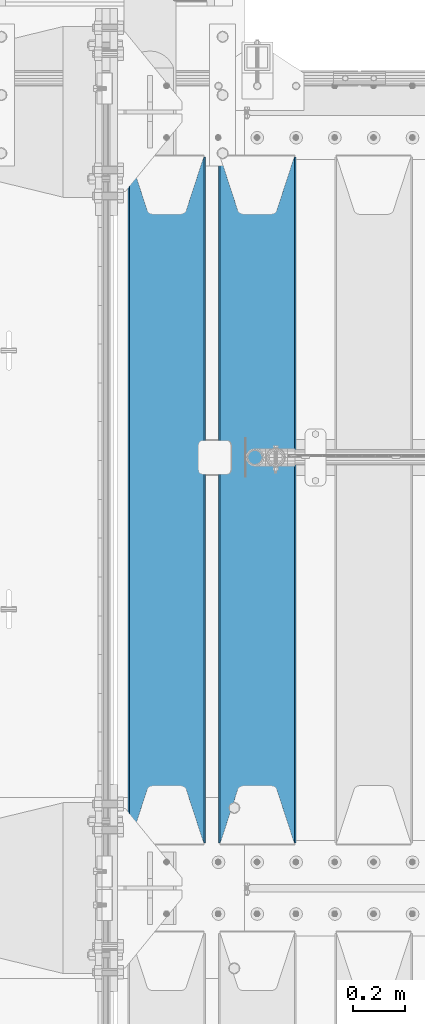
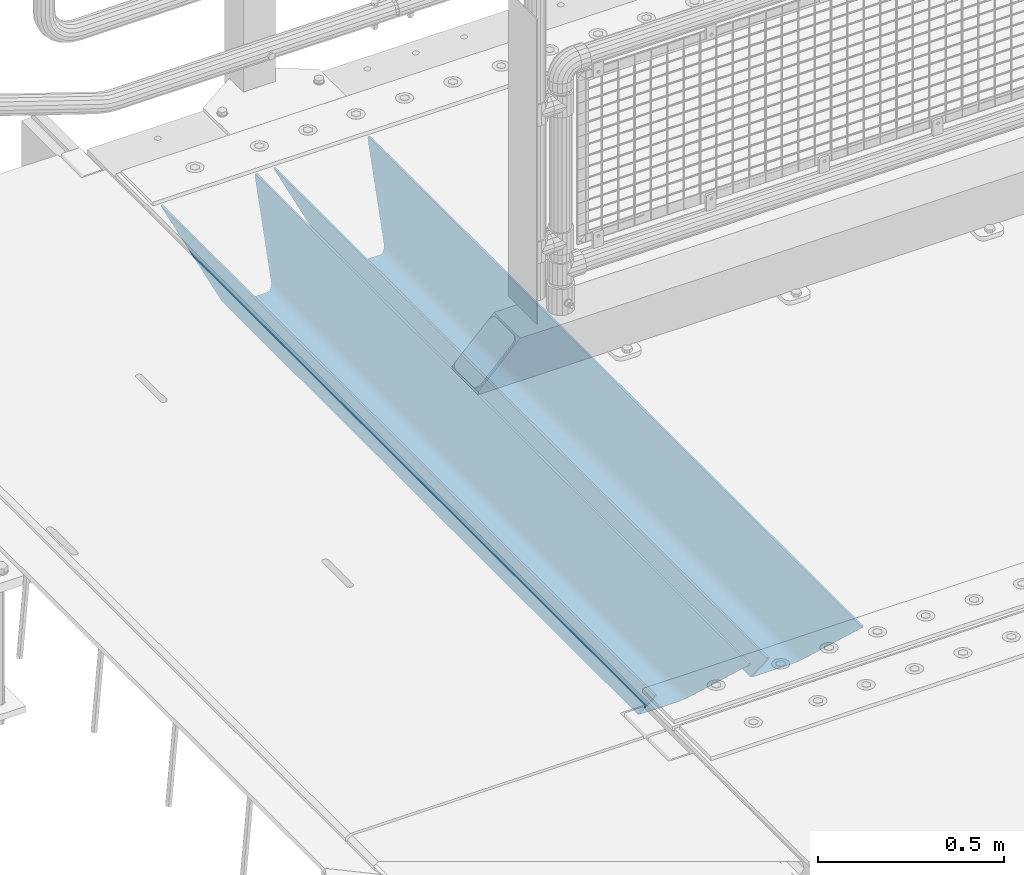
# One storey, part 127 of 270: 2 beams.
"""IFC2X3 building model written with IfcOpenShell, lengths in millimetres."""

from ifc_helpers import new_model, si_unit, frame, origin_with_axes, place, context, subcontext, project, spatial, faceted_brep, material, type_object, element, save


model = new_model("IFC2X3")

# Units and contexts
model_context = context("Model", 3, precision=1e-05, world=origin_with_axes())
body_context = subcontext(model_context, "Body", "Model", "MODEL_VIEW")
ifc_project = project(units=[si_unit("LENGTHUNIT", "METRE", prefix="MILLI"), si_unit("AREAUNIT", "SQUARE_METRE"), si_unit("VOLUMEUNIT", "CUBIC_METRE"), si_unit("MASSUNIT", "GRAM", prefix="KILO"), si_unit("TIMEUNIT", "SECOND"), si_unit("PLANEANGLEUNIT", "RADIAN"), si_unit("SOLIDANGLEUNIT", "STERADIAN"), si_unit("THERMODYNAMICTEMPERATUREUNIT", "DEGREE_CELSIUS"), si_unit("LUMINOUSINTENSITYUNIT", "LUMEN")], contexts=[model_context])

# Site, building, storey
site_placement = place(None, origin_with_axes())
site = spatial("IfcSite", under=ifc_project, at=site_placement, CompositionType="ELEMENT")
building_placement = place(site_placement, origin_with_axes())
building = spatial("IfcBuilding", under=site, at=building_placement, Name="Standard", CompositionType="ELEMENT")
storey_placement = place(building_placement, origin_with_axes())
storey = spatial("IfcBuildingStorey", under=building, at=storey_placement, Name="Undefined", CompositionType="ELEMENT", Elevation=0.0)

# Beams
ifc_material = material(Name="STEEL/S355N")
beam_type = type_object("IfcBeamType", PredefinedType="NOTDEFINED")
beam_1_placement = place(storey_placement, frame((550.0, -17825.0, -115.0), z_axis=(0.0, 0.0, 1.0), x_axis=(0.0, 1.0, 0.0)))
element("IfcBeam", 1, at=beam_1_placement, inside=storey, type_object=beam_type, material=ifc_material, context=body_context, shape_type="Brep", body=[
    faceted_brep([(0.0, 150.0, 115.0), (0.0, 143.689999999999, 115.0), (2650.00000000297, 143.689999999999, 115.0), (2650.00000000297, 150.0, 115.0), (2650.00000000297, 142.059565218398, 110.000000003096), (2650.00000000297, 148.3695652184, 110.000000003096), (2441.90079219209, -80.1103600731112, -98.0992078077845), (2437.7588105432, -77.5672621345584, -102.241189456673), (2434.06523489747, -74.4080125315522, -105.934765102404), (2430.9108609509, -70.710272125576, -109.089139048974), (2428.37322971128, -66.5649389910068, -111.626770288588), (2426.51472138055, -62.0739139532889, -113.485278619323), (2425.38102192092, -57.3475956567672, -114.618978078955), (2424.99999999987, -52.5021667386536, -115.0), (2424.99999999987, 52.5021667386536, -115.0), (2425.38102192092, 57.3475956567672, -114.618978078955), (2426.51472138055, 62.0739139532889, -113.485278619323), (2428.37322971128, 66.5649389910068, -111.626770288588), (2430.9108609509, 70.710272125576, -109.089139048974), (2434.06523489747, 74.4080125315522, -105.934765102404), (2437.7588105432, 77.5672621345584, -102.241189456673), (2441.90079219209, 80.1103600731112, -98.0992078077846), (2446.38936140511, 81.9747917625791, -93.6106385947584), (2448.2494850041, 76.2713538057251, -91.7505149957729), (2444.62967112263, 74.76777986261, -95.3703288772456), (2441.28936334126, 72.7168944282894, -98.710636658607), (2438.31067330439, 70.1691124903846, -101.689326695487), (2435.76682334747, 67.1870637758839, -104.233176652398), (2433.72034654133, 63.8440531834895, -106.279653458539), (2432.22154950042, 60.222258798236, -107.778450499454), (2431.30727574265, 56.4107117849089, -108.692724257221), (2430.99999999987, 52.5031078186876, -109.0), (2430.99999999987, -52.5031078186876, -109.0), (2431.30727574265, -56.4107117849089, -108.692724257221), (2432.22154950042, -60.222258798236, -107.778450499454), (2433.72034654133, -63.8440531834895, -106.279653458539), (2435.76682334747, -67.1870637758839, -104.233176652398), (2438.31067330438, -70.1691124903846, -101.689326695487), (2441.28936334126, -72.7168944282894, -98.7106366586071), (2444.62967112263, -74.76777986261, -95.3703288772457), (2448.2494850041, -76.2713538057251, -91.7505149957729), (2650.00000000297, -142.059565218398, 110.000000003096), (2650.00000000297, -148.3695652184, 110.000000003096), (2446.38936140511, -81.9747917625791, -93.6106385947584), (2650.00000000297, -143.689999999999, 115.0), (2650.00000000297, -150.0, 115.0), (0.0, -143.689999999999, 115.0), (0.0, -150.0, 115.0), (0.0, -148.369565218261, 110.000000002672), (203.610638597431, -81.9747917625791, -93.6106385947584), (208.099207810457, -80.1103600731112, -98.0992078077845), (212.241189459342, -77.5672621345584, -102.241189456673), (215.934765105078, -74.4080125315522, -105.934765102404), (219.089139051644, -70.710272125576, -109.089139048974), (221.626770291259, -66.5649389910068, -111.626770288588), (223.485278621993, -62.0739139532889, -113.485278619323), (224.618978081628, -57.3475956567672, -114.618978078955), (225.00000000267, -52.5021667386536, -115.0), (225.00000000267, 52.5021667386536, -115.0), (224.618978081628, 57.3475956567672, -114.618978078955), (223.485278621993, 62.0739139532889, -113.485278619323), (221.626770291259, 66.5649389910068, -111.626770288588), (219.089139051644, 70.710272125576, -109.089139048974), (215.934765105078, 74.4080125315522, -105.934765102404), (212.241189459342, 77.5672621345584, -102.241189456673), (208.099207810457, 80.1103600731112, -98.0992078077846), (203.610638597431, 81.9747917625791, -93.6106385947584), (0.0, 148.369565218261, 110.000000002672), (0.0, 142.05956521826, 110.000000002672), (201.750514998446, 76.2713538057251, -91.7505149957729), (205.370328879915, 74.76777986261, -95.3703288772456), (208.710636661279, 72.7168944282894, -98.710636658607), (211.689326698157, 70.1691124903846, -101.689326695487), (214.233176655071, 67.1870637758839, -104.233176652398), (216.27965346121, 63.8440531834895, -106.279653458539), (217.778450502126, 60.222258798236, -107.778450499454), (218.692724259894, 56.4107117849089, -108.692724257221), (219.00000000267, 52.5031078186876, -109.0), (219.00000000267, -52.5031078186876, -109.0), (218.692724259894, -56.4107117849089, -108.692724257221), (217.778450502123, -60.222258798236, -107.778450499454), (216.27965346121, -63.8440531834895, -106.279653458539), (214.233176655071, -67.1870637758839, -104.233176652398), (211.689326698157, -70.1691124903846, -101.689326695487), (208.710636661279, -72.7168944282894, -98.7106366586071), (205.370328879915, -74.76777986261, -95.3703288772457), (201.750514998446, -76.2713538057251, -91.7505149957729), (0.0, -142.05956521826, 110.000000002672)], [[[0, 1, 2, 3]], [[3, 2, 4, 5]], [[6, 7, 8, 9, 10, 11, 12, 13, 14, 15, 16, 17, 18, 19, 20, 21, 22, 5, 4, 23, 24, 25, 26, 27, 28, 29, 30, 31, 32, 33, 34, 35, 36, 37, 38, 39, 40, 41, 42, 43]], [[44, 45, 42, 41]], [[46, 47, 45, 44]], [[43, 42, 45, 47, 48, 49]], [[6, 43, 49, 50]], [[7, 6, 50, 51]], [[8, 7, 51, 52]], [[9, 8, 52, 53]], [[10, 9, 53, 54]], [[11, 10, 54, 55]], [[12, 11, 55, 56]], [[13, 12, 56, 57]], [[14, 13, 57, 58]], [[15, 14, 58, 59]], [[16, 15, 59, 60]], [[17, 16, 60, 61]], [[18, 17, 61, 62]], [[19, 18, 62, 63]], [[20, 19, 63, 64]], [[21, 20, 64, 65]], [[22, 21, 65, 66]], [[0, 3, 5, 22, 66, 67]], [[1, 0, 67, 68]], [[23, 4, 2, 1, 68, 69]], [[24, 23, 69, 70]], [[25, 24, 70, 71]], [[26, 25, 71, 72]], [[27, 26, 72, 73]], [[28, 27, 73, 74]], [[29, 28, 74, 75]], [[30, 29, 75, 76]], [[31, 30, 76, 77]], [[32, 31, 77, 78]], [[33, 32, 78, 79]], [[34, 33, 79, 80]], [[35, 34, 80, 81]], [[36, 35, 81, 82]], [[37, 36, 82, 83]], [[38, 37, 83, 84]], [[39, 38, 84, 85]], [[40, 39, 85, 86]], [[46, 44, 41, 40, 86, 87]], [[47, 46, 87, 48]], [[86, 85, 84, 83, 82, 81, 80, 79, 78, 77, 76, 75, 74, 73, 72, 71, 70, 69, 68, 67, 66, 65, 64, 63, 62, 61, 60, 59, 58, 57, 56, 55, 54, 53, 52, 51, 50, 49, 48, 87]]]),
])
beam_2_placement = place(storey_placement, frame((200.0, -17825.0, -115.0), z_axis=(0.0, 0.0, 1.0), x_axis=(0.0, 1.0, 0.0)))
element("IfcBeam", 2, at=beam_2_placement, inside=storey, type_object=beam_type, material=ifc_material, context=body_context, shape_type="Brep", body=[
    faceted_brep([(0.0, 150.0, 115.0), (0.0, 143.689999999999, 115.0), (2650.00000000297, 143.689999999999, 115.0), (2650.00000000297, 150.0, 115.0), (2650.00000000297, 142.059565218398, 110.000000003096), (2650.00000000297, 148.3695652184, 110.000000003096), (2441.90079219209, -80.1103600731112, -98.0992078077845), (2437.7588105432, -77.5672621345584, -102.241189456673), (2434.06523489747, -74.4080125315522, -105.934765102404), (2430.9108609509, -70.710272125576, -109.089139048974), (2428.37322971128, -66.5649389910068, -111.626770288588), (2426.51472138055, -62.0739139532889, -113.485278619323), (2425.38102192092, -57.3475956567672, -114.618978078955), (2424.99999999987, -52.5021667386536, -115.0), (2424.99999999987, 52.5021667386536, -115.0), (2425.38102192092, 57.3475956567672, -114.618978078955), (2426.51472138055, 62.0739139532889, -113.485278619323), (2428.37322971128, 66.5649389910068, -111.626770288588), (2430.9108609509, 70.710272125576, -109.089139048974), (2434.06523489747, 74.4080125315522, -105.934765102404), (2437.7588105432, 77.5672621345584, -102.241189456673), (2441.90079219209, 80.1103600731112, -98.0992078077846), (2446.38936140511, 81.9747917625791, -93.6106385947584), (2448.2494850041, 76.2713538057251, -91.7505149957729), (2444.62967112263, 74.76777986261, -95.3703288772456), (2441.28936334126, 72.7168944282894, -98.710636658607), (2438.31067330439, 70.1691124903846, -101.689326695487), (2435.76682334747, 67.1870637758839, -104.233176652398), (2433.72034654133, 63.8440531834895, -106.279653458539), (2432.22154950042, 60.222258798236, -107.778450499454), (2431.30727574265, 56.4107117849089, -108.692724257221), (2430.99999999987, 52.5031078186876, -109.0), (2430.99999999987, -52.5031078186876, -109.0), (2431.30727574265, -56.4107117849089, -108.692724257221), (2432.22154950042, -60.222258798236, -107.778450499454), (2433.72034654133, -63.8440531834895, -106.279653458539), (2435.76682334747, -67.1870637758839, -104.233176652398), (2438.31067330438, -70.1691124903846, -101.689326695487), (2441.28936334126, -72.7168944282894, -98.7106366586071), (2444.62967112263, -74.76777986261, -95.3703288772457), (2448.2494850041, -76.2713538057251, -91.7505149957729), (2650.00000000297, -142.059565218398, 110.000000003096), (2650.00000000297, -148.3695652184, 110.000000003096), (2446.38936140511, -81.9747917625791, -93.6106385947584), (2650.00000000297, -143.689999999999, 115.0), (2650.00000000297, -150.0, 115.0), (0.0, -143.689999999999, 115.0), (0.0, -150.0, 115.0), (0.0, -148.369565218261, 110.000000002672), (203.610638597431, -81.9747917625791, -93.6106385947584), (208.099207810457, -80.1103600731112, -98.0992078077845), (212.241189459342, -77.5672621345584, -102.241189456673), (215.934765105078, -74.4080125315522, -105.934765102404), (219.089139051644, -70.710272125576, -109.089139048974), (221.626770291259, -66.5649389910068, -111.626770288588), (223.485278621993, -62.0739139532889, -113.485278619323), (224.618978081628, -57.3475956567672, -114.618978078955), (225.00000000267, -52.5021667386536, -115.0), (225.00000000267, 52.5021667386536, -115.0), (224.618978081628, 57.3475956567672, -114.618978078955), (223.485278621993, 62.0739139532889, -113.485278619323), (221.626770291259, 66.5649389910068, -111.626770288588), (219.089139051644, 70.710272125576, -109.089139048974), (215.934765105078, 74.4080125315522, -105.934765102404), (212.241189459342, 77.5672621345584, -102.241189456673), (208.099207810457, 80.1103600731112, -98.0992078077846), (203.610638597431, 81.9747917625791, -93.6106385947584), (0.0, 148.369565218261, 110.000000002672), (0.0, 142.05956521826, 110.000000002672), (201.750514998446, 76.2713538057251, -91.7505149957729), (205.370328879915, 74.76777986261, -95.3703288772456), (208.710636661279, 72.7168944282894, -98.710636658607), (211.689326698157, 70.1691124903846, -101.689326695487), (214.233176655071, 67.1870637758839, -104.233176652398), (216.27965346121, 63.8440531834895, -106.279653458539), (217.778450502126, 60.222258798236, -107.778450499454), (218.692724259894, 56.4107117849089, -108.692724257221), (219.00000000267, 52.5031078186876, -109.0), (219.00000000267, -52.5031078186876, -109.0), (218.692724259894, -56.4107117849089, -108.692724257221), (217.778450502123, -60.222258798236, -107.778450499454), (216.27965346121, -63.8440531834895, -106.279653458539), (214.233176655071, -67.1870637758839, -104.233176652398), (211.689326698157, -70.1691124903846, -101.689326695487), (208.710636661279, -72.7168944282894, -98.7106366586071), (205.370328879915, -74.76777986261, -95.3703288772457), (201.750514998446, -76.2713538057251, -91.7505149957729), (0.0, -142.05956521826, 110.000000002672)], [[[0, 1, 2, 3]], [[3, 2, 4, 5]], [[6, 7, 8, 9, 10, 11, 12, 13, 14, 15, 16, 17, 18, 19, 20, 21, 22, 5, 4, 23, 24, 25, 26, 27, 28, 29, 30, 31, 32, 33, 34, 35, 36, 37, 38, 39, 40, 41, 42, 43]], [[44, 45, 42, 41]], [[46, 47, 45, 44]], [[43, 42, 45, 47, 48, 49]], [[6, 43, 49, 50]], [[7, 6, 50, 51]], [[8, 7, 51, 52]], [[9, 8, 52, 53]], [[10, 9, 53, 54]], [[11, 10, 54, 55]], [[12, 11, 55, 56]], [[13, 12, 56, 57]], [[14, 13, 57, 58]], [[15, 14, 58, 59]], [[16, 15, 59, 60]], [[17, 16, 60, 61]], [[18, 17, 61, 62]], [[19, 18, 62, 63]], [[20, 19, 63, 64]], [[21, 20, 64, 65]], [[22, 21, 65, 66]], [[0, 3, 5, 22, 66, 67]], [[1, 0, 67, 68]], [[23, 4, 2, 1, 68, 69]], [[24, 23, 69, 70]], [[25, 24, 70, 71]], [[26, 25, 71, 72]], [[27, 26, 72, 73]], [[28, 27, 73, 74]], [[29, 28, 74, 75]], [[30, 29, 75, 76]], [[31, 30, 76, 77]], [[32, 31, 77, 78]], [[33, 32, 78, 79]], [[34, 33, 79, 80]], [[35, 34, 80, 81]], [[36, 35, 81, 82]], [[37, 36, 82, 83]], [[38, 37, 83, 84]], [[39, 38, 84, 85]], [[40, 39, 85, 86]], [[46, 44, 41, 40, 86, 87]], [[47, 46, 87, 48]], [[86, 85, 84, 83, 82, 81, 80, 79, 78, 77, 76, 75, 74, 73, 72, 71, 70, 69, 68, 67, 66, 65, 64, 63, 62, 61, 60, 59, 58, 57, 56, 55, 54, 53, 52, 51, 50, 49, 48, 87]]]),
])

save(model, "model.ifc")
